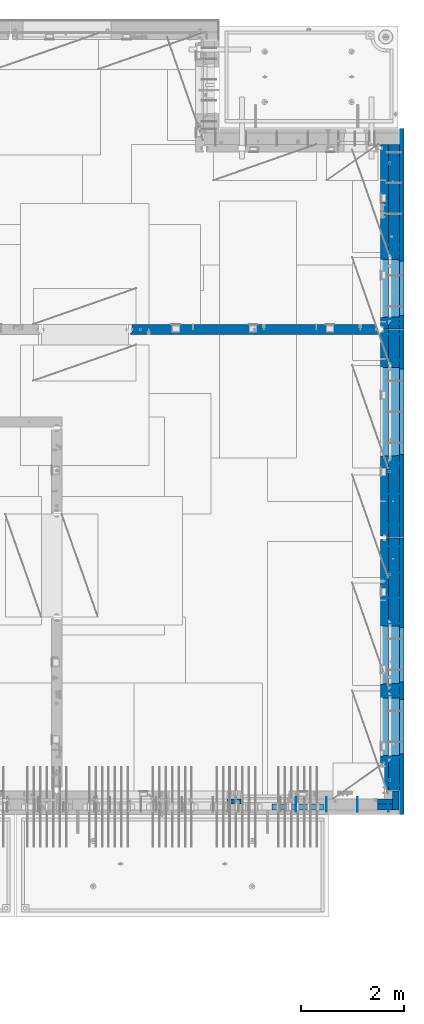
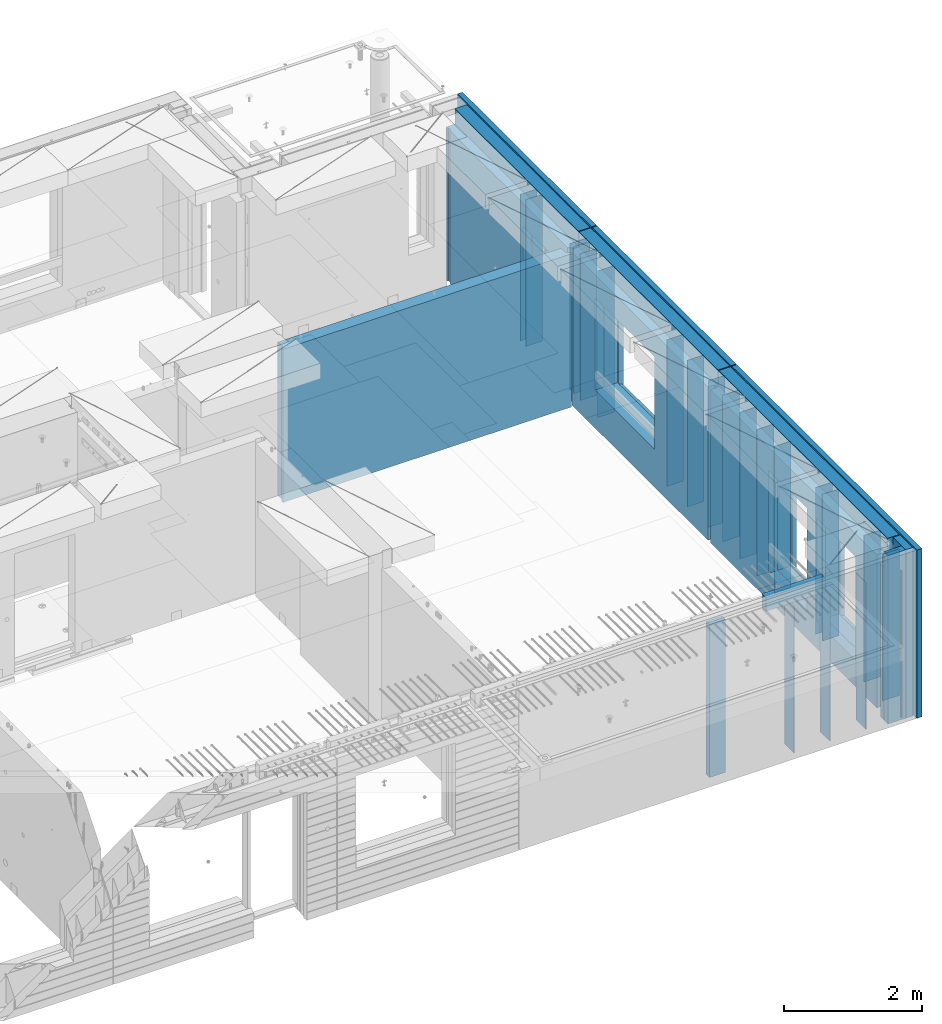
# One storey, part 243 of 352: 37 walls, 7 elements without a shape of their own.
"""IFC2X3 building model written with IfcOpenShell, lengths in millimetres."""

import ifcopenshell
import ifcopenshell.guid

model = None  # the IFC model being written
_history = None  # IfcOwnerHistory: only IFC2X3 demands one
_inside = {}  # id of a spatial element -> (the spatial element, [elements in it])
_under = {}  # id of a project, library or spatial element -> (it, [spatial elements below it])
_declared = {}  # id of a project -> (the project, [libraries it declares])
_typed = {}  # id of a type object -> (the type object, [elements of that type])
_made_of = {}  # id of a material, layer set ... -> (it, [elements and type objects made of it])


def new_model(schema):
    """Start an empty IFC model of exactly this schema.

    Asked for "IFC4X3", IfcOpenShell would pick the latest addendum, in which some entities
    have other attributes; the version numbers below select the first issue.
    IFC2X3 requires an IfcOwnerHistory on every rooted entity: one is made here for all.
    """
    global model, _history
    if schema == "IFC4X3":
        model = ifcopenshell.file(schema_version=(4, 3, 0, 0))
    else:
        model = ifcopenshell.file(schema=schema)
    _inside.clear()
    _under.clear()
    _declared.clear()
    _typed.clear()
    _made_of.clear()
    _history = None
    if model.schema == "IFC2X3":
        org = make("IfcOrganization", Name="unknown")
        user = make(
            "IfcPersonAndOrganization",
            ThePerson=make("IfcPerson", FamilyName="unknown"),
            TheOrganization=org,
        )
        app = make(
            "IfcApplication",
            ApplicationDeveloper=org,
            Version="unknown",
            ApplicationFullName="unknown",
            ApplicationIdentifier="unknown",
        )
        _history = make(
            "IfcOwnerHistory",
            OwningUser=user,
            OwningApplication=app,
            ChangeAction="ADDED",
            CreationDate=0,
        )
    return model


def make(cls, **values):
    """One entity of the class cls with the attributes given. An attribute that is None is left unset."""
    return model.create_entity(
        cls, **{name: value for name, value in values.items() if value is not None}
    )


def rooted(cls, **values):
    """An entity with a GlobalId (a new one), such as an element, a storey or a relation."""
    return make(cls, GlobalId=ifcopenshell.guid.new(), OwnerHistory=_history, **values)


def si_unit(unit_type, name, prefix=None):
    """IfcSIUnit, for example si_unit("LENGTHUNIT", "METRE", prefix="MILLI")."""
    return make("IfcSIUnit", UnitType=unit_type, Prefix=prefix, Name=name)


def assignment(units):
    """IfcUnitAssignment: the units of a project."""
    return None if units is None else make("IfcUnitAssignment", Units=units)


def point(xyz):
    """IfcCartesianPoint."""
    return None if xyz is None else make("IfcCartesianPoint", Coordinates=xyz)


def direction(xyz):
    """IfcDirection."""
    return None if xyz is None else make("IfcDirection", DirectionRatios=xyz)


def frame(location, z_axis=None, x_axis=None):
    """IfcAxis2Placement3D, a coordinate frame: its origin and axes. An axis left out is left unset."""
    return make(
        "IfcAxis2Placement3D",
        Location=point(location),
        Axis=direction(z_axis),
        RefDirection=direction(x_axis),
    )


def origin_with_axes():
    """The frame at (0, 0, 0) with the z axis (0, 0, 1) and the x axis (1, 0, 0) written out."""
    return frame((0.0, 0.0, 0.0), z_axis=(0.0, 0.0, 1.0), x_axis=(1.0, 0.0, 0.0))


def place(relative_to, where):
    """IfcLocalPlacement: puts the frame where relative to a parent placement (None: the world)."""
    return make(
        "IfcLocalPlacement", PlacementRelTo=relative_to, RelativePlacement=where
    )


def context(
    kind, dimensions, precision=None, world=None, true_north=None, identifier=None
):
    """IfcGeometricRepresentationContext, for example the 3D "Model" context."""
    return make(
        "IfcGeometricRepresentationContext",
        ContextIdentifier=identifier,
        ContextType=kind,
        CoordinateSpaceDimension=dimensions,
        Precision=precision,
        WorldCoordinateSystem=world,
        TrueNorth=true_north,
    )


def subcontext(parent, identifier, kind, view, scale=None):
    """IfcGeometricRepresentationSubContext, for example "Body" below "Model"."""
    return make(
        "IfcGeometricRepresentationSubContext",
        ContextIdentifier=identifier,
        ContextType=kind,
        ParentContext=parent,
        TargetScale=scale,
        TargetView=view,
    )


def project(units=None, contexts=None):
    """IfcProject with its units and contexts."""
    return rooted(
        "IfcProject",
        Name="project",
        RepresentationContexts=contexts,
        UnitsInContext=assignment(units),
    )


def spatial(cls, under=None, at=None, **own):
    """A site, building, storey or space (cls), placed at a placement, below another one or the project."""
    s = rooted(cls, ObjectPlacement=at, **own)
    if under is not None:
        _under.setdefault(under.id(), (under, []))[1].append(s)
    return s


def faces_of(points, faces, orient=None, outer=None):
    """IfcFace entities. A face is a list of loops; a loop is a list of indices into points, from 0.

    orient and outer hold one flag for each loop. By default every Orientation is true, the
    first loop of a face is its IfcFaceOuterBound and the others are IfcFaceBound.
    """
    made = []
    for i, loops in enumerate(faces):
        bounds = []
        for j, loop in enumerate(loops):
            is_outer = j == 0 if outer is None else outer[i][j]
            bounds.append(
                make(
                    "IfcFaceOuterBound" if is_outer else "IfcFaceBound",
                    Bound=make("IfcPolyLoop", Polygon=[points[k] for k in loop]),
                    Orientation=True if orient is None else orient[i][j],
                )
            )
        made.append(make("IfcFace", Bounds=bounds))
    return made


def faceted_brep(points, faces, orient=None, outer=None, voids=None):
    """IfcFacetedBrep: a solid bounded by flat faces; with voids (closed shells), ...WithVoids."""
    shared = [point(p) for p in points]
    hull = make("IfcClosedShell", CfsFaces=faces_of(shared, faces, orient, outer))
    if voids is None:
        return make("IfcFacetedBrep", Outer=hull)
    return make(
        "IfcFacetedBrepWithVoids",
        Outer=hull,
        Voids=[
            make(cls, CfsFaces=faces_of(shared, fs, o, b)) for cls, fs, o, b in voids
        ],
    )


def shape(context_of_items, identifier, shape_type, items):
    """IfcShapeRepresentation: the items that make up one representation, for example the "Body"."""
    return make(
        "IfcShapeRepresentation",
        ContextOfItems=context_of_items,
        RepresentationIdentifier=identifier,
        RepresentationType=shape_type,
        Items=items,
    )


def material(Name=None, Category=None):
    """IfcMaterial."""
    return make("IfcMaterial", Name=Name, Category=Category)


def made_of(thing, what):
    """Note that an element or type object is made of a material, layer set ...; save() writes the relation."""
    if what is not None:
        _made_of.setdefault(what.id(), (what, []))[1].append(thing)
    return thing


def type_object(cls, material=None, **own):
    """A type object (cls), such as IfcWallType, which elements share."""
    return made_of(rooted(cls, **own), material)


def element(
    cls,
    number,
    at=None,
    inside=None,
    cuts=None,
    type_object=None,
    material=None,
    context=None,
    identifier="Body",
    shape_type=None,
    held_by="IfcProductDefinitionShape",
    body=None,
    shapes=None,
    **own,
):
    """One element of the class cls, such as IfcWall. Its Tag is "e" and its number.

    at: its placement. inside: the storey or other place that contains it. cuts: it is an
    opening in that element (IfcRelVoidsElement). A single representation is given by context,
    identifier, shape_type and body (its items); several are given by shapes. held_by: the class
    of the entity that holds the representations. save() writes the other relations.
    """
    e = rooted(cls, Tag="e%d" % number, ObjectPlacement=at, **own)
    if body is not None:
        shapes = [shape(context, identifier, shape_type, body)]
    if shapes is not None:
        e.Representation = make(held_by, Representations=shapes)
    if inside is not None:
        _inside.setdefault(inside.id(), (inside, []))[1].append(e)
    if cuts is not None:
        rooted(
            "IfcRelVoidsElement", RelatingBuildingElement=cuts, RelatedOpeningElement=e
        )
    if type_object is not None:
        _typed.setdefault(type_object.id(), (type_object, []))[1].append(e)
    return made_of(e, material)


def aggregate(whole, parts):
    """IfcRelAggregates: a whole, such as a stair, and the parts it consists of."""
    return rooted("IfcRelAggregates", RelatingObject=whole, RelatedObjects=parts)


def save(model, path):
    """Write the relations noted so far, then the file.

    IfcRelAggregates (storeys below a building ...), IfcRelContainedInSpatialStructure (elements
    in a storey), IfcRelDefinesByType, IfcRelAssociatesMaterial and IfcRelDeclares: one each for
    every whole, place, type object, material and project.
    """
    for whole, parts in _under.values():
        aggregate(whole, parts)
    for where, things in _inside.values():
        rooted(
            "IfcRelContainedInSpatialStructure",
            RelatedElements=things,
            RelatingStructure=where,
        )
    for kind, things in _typed.values():
        rooted("IfcRelDefinesByType", RelatedObjects=things, RelatingType=kind)
    for what, things in _made_of.values():
        rooted("IfcRelAssociatesMaterial", RelatedObjects=things, RelatingMaterial=what)
    for by, libraries in _declared.values():
        rooted("IfcRelDeclares", RelatingContext=by, RelatedDefinitions=libraries)
    model.write(path)


model = new_model("IFC2X3")

# Units and contexts
model_context = context("Model", 3, precision=1e-05, world=origin_with_axes())
body_context = subcontext(model_context, "Body", "Model", "MODEL_VIEW")
ifc_project = project(units=[si_unit("LENGTHUNIT", "METRE", prefix="MILLI"), si_unit("AREAUNIT", "SQUARE_METRE"), si_unit("VOLUMEUNIT", "CUBIC_METRE"), si_unit("MASSUNIT", "GRAM", prefix="KILO"), si_unit("TIMEUNIT", "SECOND"), si_unit("PLANEANGLEUNIT", "RADIAN"), si_unit("SOLIDANGLEUNIT", "STERADIAN"), si_unit("THERMODYNAMICTEMPERATUREUNIT", "DEGREE_CELSIUS"), si_unit("LUMINOUSINTENSITYUNIT", "LUMEN")], contexts=[model_context])

# Site, building, storey
site_placement = place(None, origin_with_axes())
site = spatial("IfcSite", under=ifc_project, at=site_placement, CompositionType="ELEMENT")
building_placement = place(site_placement, origin_with_axes())
building = spatial("IfcBuilding", under=site, at=building_placement, CompositionType="ELEMENT")
storey_placement = place(building_placement, origin_with_axes())
storey = spatial("IfcBuildingStorey", under=building, at=storey_placement, Name="6", CompositionType="ELEMENT", Elevation=0.0)

# Assembly, walls
assembly_1_placement = place(storey_placement, origin_with_axes())
assembly_1 = element("IfcElementAssembly", 1, at=assembly_1_placement, inside=storey, AssemblyPlace="NOTDEFINED", PredefinedType="REINFORCEMENT_UNIT")
ifc_material_1 = material(Name="Undefined")
wall_type_1 = type_object("IfcWallType", PredefinedType="NOTDEFINED")
wall_1_placement = place(assembly_1_placement, frame((35030.0, 18465.0002441406, 98115.0), z_axis=(0.0, 0.0, 1.0), x_axis=(1.0, 0.0, 0.0)))
wall_1 = element("IfcWall", 2, at=wall_1_placement, type_object=wall_type_1, material=ifc_material_1, Name="(PD)", context=body_context, shape_type="Brep", body=[
    faceted_brep([(0.0, 5.0, -1300.0), (0.0, 5.0, 1300.0), (280.0, 5.0, 1300.0), (280.0, 5.0, -1300.0), (0.0, -5.0, 1300.0), (280.0, -5.0, 1300.0), (0.0, -5.0, -1300.0), (280.0, -5.0, -1300.0)], [[[0, 1, 2, 3]], [[1, 4, 5, 2]], [[4, 6, 7, 5]], [[6, 0, 3, 7]], [[5, 7, 3, 2]], [[6, 4, 1, 0]]]),
])
wall_2_placement = place(assembly_1_placement, frame((35030.0, 17085.0002441406, 98115.0), z_axis=(0.0, 0.0, 1.0), x_axis=(1.0, 0.0, 0.0)))
wall_2 = element("IfcWall", 3, at=wall_2_placement, type_object=wall_type_1, material=ifc_material_1, Name="(PD)", context=body_context, shape_type="Brep", body=[
    faceted_brep([(0.0, 5.0, -1300.0), (0.0, 5.0, 1300.0), (280.0, 5.0, 1300.0), (280.0, 5.0, -1300.0), (0.0, -5.0, 1300.0), (280.0, -5.0, 1300.0), (0.0, -5.0, -1300.0), (280.0, -5.0, -1300.0)], [[[0, 1, 2, 3]], [[1, 4, 5, 2]], [[4, 6, 7, 5]], [[6, 0, 3, 7]], [[5, 7, 3, 2]], [[6, 4, 1, 0]]]),
])
wall_3_placement = place(assembly_1_placement, frame((35030.0, 17185.0002441406, 98115.0), z_axis=(0.0, 0.0, 1.0), x_axis=(1.0, 0.0, 0.0)))
wall_3 = element("IfcWall", 4, at=wall_3_placement, type_object=wall_type_1, material=ifc_material_1, Name="(PD)", context=body_context, shape_type="Brep", body=[
    faceted_brep([(0.0, 5.0, -1300.0), (0.0, 5.0, 1300.0), (280.0, 5.0, 1300.0), (280.0, 5.0, -1300.0), (0.0, -5.0, 1300.0), (280.0, -5.0, 1300.0), (0.0, -5.0, -1300.0), (280.0, -5.0, -1300.0)], [[[0, 1, 2, 3]], [[1, 4, 5, 2]], [[4, 6, 7, 5]], [[6, 0, 3, 7]], [[5, 7, 3, 2]], [[6, 4, 1, 0]]]),
])
wall_4_placement = place(assembly_1_placement, frame((35030.0, 18625.0002441406, 98115.0), z_axis=(0.0, 0.0, 1.0), x_axis=(1.0, 0.0, 0.0)))
wall_4 = element("IfcWall", 5, at=wall_4_placement, type_object=wall_type_1, material=ifc_material_1, Name="(PD)", context=body_context, shape_type="Brep", body=[
    faceted_brep([(0.0, 5.0, -1300.0), (0.0, 5.0, 1300.0), (280.0, 5.0, 1300.0), (280.0, 5.0, -1300.0), (0.0, -5.0, 1300.0), (280.0, -5.0, 1300.0), (0.0, -5.0, -1300.0), (280.0, -5.0, -1300.0)], [[[0, 1, 2, 3]], [[1, 4, 5, 2]], [[4, 6, 7, 5]], [[6, 0, 3, 7]], [[5, 7, 3, 2]], [[6, 4, 1, 0]]]),
])

assembly_2_placement = place(storey_placement, origin_with_axes())
assembly_2 = element("IfcElementAssembly", 6, at=assembly_2_placement, inside=storey, AssemblyPlace="NOTDEFINED", PredefinedType="REINFORCEMENT_UNIT")
wall_5_placement = place(assembly_2_placement, frame((35060.0, 7780.0, 98115.0), z_axis=(0.0, 0.0, 1.0), x_axis=(0.0, -1.0, 0.0)))
wall_5 = element("IfcWall", 7, at=wall_5_placement, type_object=wall_type_1, material=ifc_material_1, Name="(PD)", context=body_context, shape_type="Brep", body=[
    faceted_brep([(0.0, 5.0, -1300.0), (0.0, 5.0, 1300.0), (180.0, 5.0, 1300.0), (180.0, 5.0, -1300.0), (0.0, -5.0, 1300.0), (180.0, -5.0, 1300.0), (0.0, -5.0, -1300.0), (180.0, -5.0, -1300.0)], [[[0, 1, 2, 3]], [[1, 4, 5, 2]], [[4, 6, 7, 5]], [[6, 0, 3, 7]], [[5, 7, 3, 2]], [[6, 4, 1, 0]]]),
])
wall_6_placement = place(assembly_2_placement, frame((34460.0, 7880.0, 98115.0), z_axis=(0.0, 0.0, 1.0), x_axis=(0.0, -1.0, 0.0)))
wall_6 = element("IfcWall", 8, at=wall_6_placement, type_object=wall_type_1, material=ifc_material_1, Name="(PD)", context=body_context, shape_type="Brep", body=[
    faceted_brep([(0.0, 5.0, -1300.0), (0.0, 5.0, 1300.0), (280.0, 5.0, 1300.0), (280.0, 5.0, -1300.0), (0.0, -5.0, 1300.0), (280.0, -5.0, 1300.0), (0.0, -5.0, -1300.0), (280.0, -5.0, -1300.0)], [[[0, 1, 2, 3]], [[1, 4, 5, 2]], [[4, 6, 7, 5]], [[6, 0, 3, 7]], [[5, 7, 3, 2]], [[6, 4, 1, 0]]]),
])
wall_7_placement = place(assembly_2_placement, frame((33860.0, 7880.0, 98115.0), z_axis=(0.0, 0.0, 1.0), x_axis=(0.0, -1.0, 0.0)))
wall_7 = element("IfcWall", 9, at=wall_7_placement, type_object=wall_type_1, material=ifc_material_1, Name="(PD)", context=body_context, shape_type="Brep", body=[
    faceted_brep([(0.0, 5.0, -1300.0), (0.0, 5.0, 1300.0), (280.0, 5.0, 1300.0), (280.0, 5.0, -1300.0), (0.0, -5.0, 1300.0), (280.0, -5.0, 1300.0), (0.0, -5.0, -1300.0), (280.0, -5.0, -1300.0)], [[[0, 1, 2, 3]], [[1, 4, 5, 2]], [[4, 6, 7, 5]], [[6, 0, 3, 7]], [[5, 7, 3, 2]], [[6, 4, 1, 0]]]),
])

assembly_3_placement = place(storey_placement, origin_with_axes())
assembly_3 = element("IfcElementAssembly", 10, at=assembly_3_placement, inside=storey, AssemblyPlace="NOTDEFINED", PredefinedType="REINFORCEMENT_UNIT")
wall_8_placement = place(assembly_3_placement, frame((35030.0, 12755.0002861023, 98115.0), z_axis=(0.0, 0.0, 1.0), x_axis=(1.0, 0.0, 0.0)))
wall_8 = element("IfcWall", 11, at=wall_8_placement, type_object=wall_type_1, material=ifc_material_1, Name="(PD)", context=body_context, shape_type="Brep", body=[
    faceted_brep([(0.0, 5.0, -1300.0), (0.0, 5.0, 1300.0), (280.0, 5.0, 1300.0), (280.0, 5.0, -1300.0), (0.0, -5.0, 1300.0), (280.0, -5.0, 1300.0), (0.0, -5.0, -1300.0), (280.0, -5.0, -1300.0)], [[[0, 1, 2, 3]], [[1, 4, 5, 2]], [[4, 6, 7, 5]], [[6, 0, 3, 7]], [[5, 7, 3, 2]], [[6, 4, 1, 0]]]),
])
wall_9_placement = place(assembly_3_placement, frame((35030.0, 12255.0002861023, 98115.0), z_axis=(0.0, 0.0, 1.0), x_axis=(1.0, 0.0, 0.0)))
wall_9 = element("IfcWall", 12, at=wall_9_placement, type_object=wall_type_1, material=ifc_material_1, Name="(PD)", context=body_context, shape_type="Brep", body=[
    faceted_brep([(0.0, 5.0, -1300.0), (0.0, 5.0, 1300.0), (280.0, 5.0, 1300.0), (280.0, 5.0, -1300.0), (0.0, -5.0, 1300.0), (280.0, -5.0, 1300.0), (0.0, -5.0, -1300.0), (280.0, -5.0, -1300.0)], [[[0, 1, 2, 3]], [[1, 4, 5, 2]], [[4, 6, 7, 5]], [[6, 0, 3, 7]], [[5, 7, 3, 2]], [[6, 4, 1, 0]]]),
])
wall_10_placement = place(assembly_3_placement, frame((35030.0, 11755.0002861023, 98115.0), z_axis=(0.0, 0.0, 1.0), x_axis=(1.0, 0.0, 0.0)))
wall_10 = element("IfcWall", 13, at=wall_10_placement, type_object=wall_type_1, material=ifc_material_1, Name="(PD)", context=body_context, shape_type="Brep", body=[
    faceted_brep([(0.0, 5.0, -1300.0), (0.0, 5.0, 1300.0), (280.0, 5.0, 1300.0), (280.0, 5.0, -1300.0), (0.0, -5.0, 1300.0), (280.0, -5.0, 1300.0), (0.0, -5.0, -1300.0), (280.0, -5.0, -1300.0)], [[[0, 1, 2, 3]], [[1, 4, 5, 2]], [[4, 6, 7, 5]], [[6, 0, 3, 7]], [[5, 7, 3, 2]], [[6, 4, 1, 0]]]),
])
wall_11_placement = place(assembly_3_placement, frame((35030.0, 11255.0002861023, 98115.0), z_axis=(0.0, 0.0, 1.0), x_axis=(1.0, 0.0, 0.0)))
wall_11 = element("IfcWall", 14, at=wall_11_placement, type_object=wall_type_1, material=ifc_material_1, Name="(PD)", context=body_context, shape_type="Brep", body=[
    faceted_brep([(0.0, 5.0, -1300.0), (0.0, 5.0, 1300.0), (280.0, 5.0, 1300.0), (280.0, 5.0, -1300.0), (0.0, -5.0, 1300.0), (280.0, -5.0, 1300.0), (0.0, -5.0, -1300.0), (280.0, -5.0, -1300.0)], [[[0, 1, 2, 3]], [[1, 4, 5, 2]], [[4, 6, 7, 5]], [[6, 0, 3, 7]], [[5, 7, 3, 2]], [[6, 4, 1, 0]]]),
])
wall_12_placement = place(assembly_3_placement, frame((35030.0, 8105.0, 98115.0), z_axis=(0.0, 0.0, 1.0), x_axis=(1.0, 0.0, 0.0)))
wall_12 = element("IfcWall", 15, at=wall_12_placement, type_object=wall_type_1, material=ifc_material_1, Name="(PD)", context=body_context, shape_type="Brep", body=[
    faceted_brep([(0.0, 5.0, -1300.0), (0.0, 5.0, 1300.0), (280.0, 5.0, 1300.0), (280.0, 5.0, -1300.0), (0.0, -5.0, 1300.0), (280.0, -5.0, 1300.0), (0.0, -5.0, -1300.0), (280.0, -5.0, -1300.0)], [[[0, 1, 2, 3]], [[1, 4, 5, 2]], [[4, 6, 7, 5]], [[6, 0, 3, 7]], [[5, 7, 3, 2]], [[6, 4, 1, 0]]]),
])
wall_13_placement = place(assembly_3_placement, frame((35030.0, 8115.0, 98115.0), z_axis=(0.0, 0.0, 1.0), x_axis=(1.0, 0.0, 0.0)))
wall_13 = element("IfcWall", 16, at=wall_13_placement, type_object=wall_type_1, material=ifc_material_1, Name="(PD)", context=body_context, shape_type="Brep", body=[
    faceted_brep([(0.0, 5.0, -1300.0), (0.0, 5.0, 1300.0), (280.0, 5.0, 1300.0), (280.0, 5.0, -1300.0), (0.0, -5.0, 1300.0), (280.0, -5.0, 1300.0), (0.0, -5.0, -1300.0), (280.0, -5.0, -1300.0)], [[[0, 1, 2, 3]], [[1, 4, 5, 2]], [[4, 6, 7, 5]], [[6, 0, 3, 7]], [[5, 7, 3, 2]], [[6, 4, 1, 0]]]),
])
wall_14_placement = place(assembly_3_placement, frame((35030.0, 9855.00028610229, 98115.0), z_axis=(0.0, 0.0, 1.0), x_axis=(1.0, 0.0, 0.0)))
wall_14 = element("IfcWall", 17, at=wall_14_placement, type_object=wall_type_1, material=ifc_material_1, Name="(PD)", context=body_context, shape_type="Brep", body=[
    faceted_brep([(0.0, 5.0, -1300.0), (0.0, 5.0, 1300.0), (280.0, 5.0, 1300.0), (280.0, 5.0, -1300.0), (0.0, -5.0, 1300.0), (280.0, -5.0, 1300.0), (0.0, -5.0, -1300.0), (280.0, -5.0, -1300.0)], [[[0, 1, 2, 3]], [[1, 4, 5, 2]], [[4, 6, 7, 5]], [[6, 0, 3, 7]], [[5, 7, 3, 2]], [[6, 4, 1, 0]]]),
])
wall_15_placement = place(assembly_3_placement, frame((35030.0, 10055.0002861023, 98115.0), z_axis=(0.0, 0.0, 1.0), x_axis=(1.0, 0.0, 0.0)))
wall_15 = element("IfcWall", 18, at=wall_15_placement, type_object=wall_type_1, material=ifc_material_1, Name="(PD)", context=body_context, shape_type="Brep", body=[
    faceted_brep([(0.0, 5.0, -1300.0), (0.0, 5.0, 1300.0), (280.0, 5.0, 1300.0), (280.0, 5.0, -1300.0), (0.0, -5.0, 1300.0), (280.0, -5.0, 1300.0), (0.0, -5.0, -1300.0), (280.0, -5.0, -1300.0)], [[[0, 1, 2, 3]], [[1, 4, 5, 2]], [[4, 6, 7, 5]], [[6, 0, 3, 7]], [[5, 7, 3, 2]], [[6, 4, 1, 0]]]),
])

assembly_4_placement = place(storey_placement, origin_with_axes())
assembly_4 = element("IfcElementAssembly", 19, at=assembly_4_placement, inside=storey, AssemblyPlace="NOTDEFINED", PredefinedType="REINFORCEMENT_UNIT")
wall_16_placement = place(assembly_4_placement, frame((35030.0, 13175.0002861023, 98115.0), z_axis=(0.0, 0.0, 1.0), x_axis=(1.0, 0.0, 0.0)))
wall_16 = element("IfcWall", 20, at=wall_16_placement, type_object=wall_type_1, material=ifc_material_1, Name="(PD)", context=body_context, shape_type="Brep", body=[
    faceted_brep([(0.0, 5.0, -1300.0), (0.0, 5.0, 1300.0), (280.0, 5.0, 1300.0), (280.0, 5.0, -1300.0), (0.0, -5.0, 1300.0), (280.0, -5.0, 1300.0), (0.0, -5.0, -1300.0), (280.0, -5.0, -1300.0)], [[[0, 1, 2, 3]], [[1, 4, 5, 2]], [[4, 6, 7, 5]], [[6, 0, 3, 7]], [[5, 7, 3, 2]], [[6, 4, 1, 0]]]),
])
wall_17_placement = place(assembly_4_placement, frame((35030.0, 13775.0002861023, 98115.0), z_axis=(0.0, 0.0, 1.0), x_axis=(1.0, 0.0, 0.0)))
wall_17 = element("IfcWall", 21, at=wall_17_placement, type_object=wall_type_1, material=ifc_material_1, Name="(PD)", context=body_context, shape_type="Brep", body=[
    faceted_brep([(0.0, 5.0, -1300.0), (0.0, 5.0, 1300.0), (280.0, 5.0, 1300.0), (280.0, 5.0, -1300.0), (0.0, -5.0, 1300.0), (280.0, -5.0, 1300.0), (0.0, -5.0, -1300.0), (280.0, -5.0, -1300.0)], [[[0, 1, 2, 3]], [[1, 4, 5, 2]], [[4, 6, 7, 5]], [[6, 0, 3, 7]], [[5, 7, 3, 2]], [[6, 4, 1, 0]]]),
])
wall_18_placement = place(assembly_4_placement, frame((35030.0, 16885.0002861023, 98115.0), z_axis=(0.0, 0.0, 1.0), x_axis=(1.0, 0.0, 0.0)))
wall_18 = element("IfcWall", 22, at=wall_18_placement, type_object=wall_type_1, material=ifc_material_1, Name="(PD)", context=body_context, shape_type="Brep", body=[
    faceted_brep([(0.0, 5.0, -1300.0), (0.0, 5.0, 1300.0), (280.0, 5.0, 1300.0), (280.0, 5.0, -1300.0), (0.0, -5.0, 1300.0), (280.0, -5.0, 1300.0), (0.0, -5.0, -1300.0), (280.0, -5.0, -1300.0)], [[[0, 1, 2, 3]], [[1, 4, 5, 2]], [[4, 6, 7, 5]], [[6, 0, 3, 7]], [[5, 7, 3, 2]], [[6, 4, 1, 0]]]),
])
wall_19_placement = place(assembly_4_placement, frame((35030.0, 16385.0002861023, 98115.0), z_axis=(0.0, 0.0, 1.0), x_axis=(1.0, 0.0, 0.0)))
wall_19 = element("IfcWall", 23, at=wall_19_placement, type_object=wall_type_1, material=ifc_material_1, Name="(PD)", context=body_context, shape_type="Brep", body=[
    faceted_brep([(0.0, 5.0, -1300.0), (0.0, 5.0, 1300.0), (280.0, 5.0, 1300.0), (280.0, 5.0, -1300.0), (0.0, -5.0, 1300.0), (280.0, -5.0, 1300.0), (0.0, -5.0, -1300.0), (280.0, -5.0, -1300.0)], [[[0, 1, 2, 3]], [[1, 4, 5, 2]], [[4, 6, 7, 5]], [[6, 0, 3, 7]], [[5, 7, 3, 2]], [[6, 4, 1, 0]]]),
])

# Wall
wall_20_placement = place(assembly_2_placement, frame((33260.0, 7880.0, 98115.0), z_axis=(0.0, 0.0, 1.0), x_axis=(0.0, -1.0, 0.0)))
wall_20 = element("IfcWall", 24, at=wall_20_placement, type_object=wall_type_1, material=ifc_material_1, Name="(PD)", context=body_context, shape_type="Brep", body=[
    faceted_brep([(0.0, 5.0, -1300.0), (0.0, 5.0, 1300.0), (280.0, 5.0, 1300.0), (280.0, 5.0, -1300.0), (0.0, -5.0, 1300.0), (280.0, -5.0, 1300.0), (0.0, -5.0, -1300.0), (280.0, -5.0, -1300.0)], [[[0, 1, 2, 3]], [[1, 4, 5, 2]], [[4, 6, 7, 5]], [[6, 0, 3, 7]], [[5, 7, 3, 2]], [[6, 4, 1, 0]]]),
])

wall_21_placement = place(assembly_3_placement, frame((35030.0, 8655.0, 98115.0), z_axis=(0.0, 0.0, 1.0), x_axis=(1.0, 0.0, 0.0)))
wall_21 = element("IfcWall", 25, at=wall_21_placement, type_object=wall_type_1, material=ifc_material_1, Name="(PD)", context=body_context, shape_type="Brep", body=[
    faceted_brep([(0.0, 5.0, -1300.0), (0.0, 5.0, 1300.0), (280.0, 5.0, 1300.0), (280.0, 5.0, -1300.0), (0.0, -5.0, 1300.0), (280.0, -5.0, 1300.0), (0.0, -5.0, -1300.0), (280.0, -5.0, -1300.0)], [[[0, 1, 2, 3]], [[1, 4, 5, 2]], [[4, 6, 7, 5]], [[6, 0, 3, 7]], [[5, 7, 3, 2]], [[6, 4, 1, 0]]]),
])

wall_22_placement = place(assembly_4_placement, frame((35030.0, 14375.0002861023, 98115.0), z_axis=(0.0, 0.0, 1.0), x_axis=(1.0, 0.0, 0.0)))
wall_22 = element("IfcWall", 26, at=wall_22_placement, type_object=wall_type_1, material=ifc_material_1, Name="(PD)", context=body_context, shape_type="Brep", body=[
    faceted_brep([(0.0, 5.0, -1300.0), (0.0, 5.0, 1300.0), (280.0, 5.0, 1300.0), (280.0, 5.0, -1300.0), (0.0, -5.0, 1300.0), (280.0, -5.0, 1300.0), (0.0, -5.0, -1300.0), (280.0, -5.0, -1300.0)], [[[0, 1, 2, 3]], [[1, 4, 5, 2]], [[4, 6, 7, 5]], [[6, 0, 3, 7]], [[5, 7, 3, 2]], [[6, 4, 1, 0]]]),
])

# Assembly, wall
assembly_5_placement = place(storey_placement, origin_with_axes())
assembly_5 = element("IfcElementAssembly", 27, at=assembly_5_placement, inside=storey, AssemblyPlace="NOTDEFINED", PredefinedType="REINFORCEMENT_UNIT")
ifc_material_2 = material(Name="CONCRETE/C25/30")
wall_type_2 = type_object("IfcWallType", PredefinedType="NOTDEFINED")
wall_23_placement = place(assembly_5_placement, frame((30040.0, 16980.0002441406, 98112.5), z_axis=(0.0, 0.0, 1.0), x_axis=(1.0, 0.0, 0.0)))
wall_23 = element("IfcWall", 28, at=wall_23_placement, type_object=wall_type_2, material=ifc_material_2, context=body_context, shape_type="Brep", body=[
    faceted_brep([(4785.0, 100.0, 1357.5), (4785.0, -30.0, 1357.5), (4785.0, -30.0, -1357.5), (4785.0, 100.0, -1357.5), (4840.0, -60.0, 1357.5), (4840.0, -60.0, -1357.5), (30.0003214753524, 100.0, 1357.5), (30.0003214753524, 100.0, -1357.5), (30.0003214753524, -57.0, -1357.5), (30.0003214753524, -57.0, 1357.5), (0.0, -70.0001393059865, -1357.5), (0.0, -70.0001393059865, 1357.5), (0.0, -100.0, -1357.5), (0.0, -100.0, 1357.5), (4840.0, -100.0, -1357.5), (4840.0, -100.0, 1357.5)], [[[0, 1, 2, 3]], [[4, 5, 2, 1]], [[6, 7, 8, 9]], [[9, 8, 10, 11]], [[12, 13, 11, 10]], [[13, 12, 14, 15]], [[0, 6, 9, 11, 13, 15, 4, 1]], [[7, 6, 0, 3]], [[14, 12, 10, 8, 7, 3, 2, 5]], [[15, 14, 5, 4]]]),
])
aggregate(assembly_5, [wall_23])

# Assemblies, wall
assembly_6_placement = place(storey_placement, origin_with_axes())
assembly_6 = element("IfcElementAssembly", 29, at=assembly_6_placement, inside=storey, AssemblyPlace="NOTDEFINED", PredefinedType="REINFORCEMENT_UNIT")
assembly_7_placement = place(assembly_6_placement, origin_with_axes())
assembly_7 = element("IfcElementAssembly", 30, at=assembly_7_placement, Name="Steel Assembly", AssemblyPlace="NOTDEFINED", PredefinedType="NOTDEFINED")
aggregate(assembly_6, [assembly_7])
ifc_material_3 = material()
wall_type_3 = type_object("IfcWallType", PredefinedType="NOTDEFINED")
wall_24_placement = place(assembly_7_placement, frame((32799.9998568133, 7690.00021946163, 99590.0), z_axis=(0.0, 0.0, 1.0), x_axis=(1.0, 0.0, 0.0)))
wall_24 = element("IfcWall", 31, at=wall_24_placement, type_object=wall_type_3, material=ifc_material_3, context=body_context, shape_type="Brep", body=[
    faceted_brep([(0.0, 60.0, -120.0), (0.0, 60.0, 120.0), (1000.0, 60.0, 120.0), (1000.0, 60.0, -120.0), (0.0, -60.0, 120.0), (1000.0, -60.0, 120.0), (0.0, -60.0, -120.0), (1000.0, -60.0, -120.0)], [[[0, 1, 2, 3]], [[1, 4, 5, 2]], [[4, 6, 7, 5]], [[6, 0, 3, 7]], [[5, 7, 3, 2]], [[6, 4, 1, 0]]]),
])
aggregate(assembly_7, [wall_24])

# Wall
ifc_material_4 = material(Name="COS5gt")
wall_type_4 = type_object("IfcWallType", PredefinedType="NOTDEFINED")
wall_25_placement = place(assembly_1_placement, frame((35170.0, 20575.0002441406, 98247.5), z_axis=(0.0, 0.0, 1.0), x_axis=(0.0, -1.0, 0.0)))
wall_25 = element("IfcWall", 32, at=wall_25_placement, type_object=wall_type_4, material=ifc_material_4, context=body_context, shape_type="Brep", body=[
    faceted_brep([(0.0, 90.0, 1492.5), (3585.0, 90.0, 1492.5), (3585.0, 90.0, 1442.5), (0.0, 90.0, 1442.5), (0.0, -110.0, 1492.5), (3585.0, -110.0, 1492.5), (3585.0, 110.0, 1442.5), (3585.0, -110.0, -1492.5), (3585.0, 90.0, -1492.5), (3585.0, 90.0, -1442.5), (3585.0, 110.0, -1442.5), (0.0, 110.0, 1442.5), (0.0, 90.0, -1492.5), (0.0, -110.0, -1492.5), (0.0, 110.0, -1442.5), (0.0, 90.0, -1442.5), (2239.99987343476, 110.0, -807.5), (2269.99987343476, 110.0, -807.5), (3319.99987343476, 110.0, -807.5), (3349.99987343476, 110.0, -807.5), (3349.99987343476, 110.0, -802.5), (3349.99987343476, 110.0, 807.5), (2239.99987343476, 110.0, 807.5), (2239.99987343476, 110.0, -802.5), (3355.94581938071, -110.0, -813.445945945947), (3355.94581938071, -110.0, 813.445945945947), (2234.05392748882, -110.0, -813.445945945947), (2234.05392748882, -110.0, 813.445945945947)], [[[0, 1, 2, 3]], [[4, 5, 1, 0]], [[6, 2, 1, 5, 7, 8, 9, 10]], [[11, 3, 2, 6]], [[12, 13, 4, 0, 3, 11, 14, 15]], [[7, 13, 12, 8]], [[15, 9, 8, 12]], [[14, 10, 9, 15]], [[11, 6, 10, 14], [16, 17, 18, 19, 20, 21, 22, 23]], [[20, 19, 24, 25, 21]], [[18, 17, 16, 26, 24, 19]], [[23, 22, 27, 26, 16]], [[21, 25, 27, 22]], [[4, 13, 7, 5], [24, 26, 27, 25]]]),
])

wall_26_placement = place(assembly_3_placement, frame((35170.0, 12920.0002861023, 98247.5), z_axis=(0.0, 0.0, 1.0), x_axis=(0.0, -1.0, 0.0)))
wall_26 = element("IfcWall", 33, at=wall_26_placement, type_object=wall_type_4, material=ifc_material_4, context=body_context, shape_type="Brep", body=[
    faceted_brep([(0.0, 90.0, 1492.5), (4905.00028610229, 90.0, 1492.5), (4905.00028610229, 90.0, 1442.5), (-0.25, 90.0, 1442.5), (0.0, -110.0, 1492.5), (4905.00028610229, -110.0, 1492.5), (4905.00028610229, 110.0, 1442.5), (4905.00028610229, -110.0, -1492.5), (4905.00028610229, 90.0, -1492.5), (4905.00028610229, 90.0, -1442.5), (4905.00028610229, 110.0, -1442.5), (-0.25, 110.0, 1442.5), (0.0, 90.0, -1492.5), (0.0, -110.0, -1492.5), (-0.25, 110.0, -1442.5), (-0.25, 90.0, -1442.5), (3115.00024333302, 110.0, -1007.5), (3145.00024333302, 110.0, -1007.5), (4195.00024333302, 110.0, -1007.5), (4225.00024333302, 110.0, -1007.5), (4225.00024333302, 110.0, -1002.5), (4225.00024333302, 110.0, 807.5), (3115.00024333302, 110.0, 807.5), (3115.00024333302, 110.0, -1002.5), (1715.00062480275, 110.0, -1007.5), (1745.00062480275, 110.0, -1007.5), (2795.00062480275, 110.0, -1007.5), (2825.00062480275, 110.0, -1007.5), (2825.00062480275, 110.0, -1002.5), (2825.00062480275, 110.0, 807.5), (1715.00062480275, 110.0, 807.5), (1715.00062480275, 110.0, -1002.5), (4230.94618927897, -110.0, -1013.44594594595), (4230.94618927897, -110.0, 813.445945945947), (3109.05429738708, -110.0, -1013.44594594595), (3109.05429738708, -110.0, 813.445945945947), (2830.9465707487, -110.0, -1013.44594594595), (1709.0546788568, -110.0, -1013.44594594595), (1709.0546788568, -110.0, 813.445945945947), (2830.9465707487, -110.0, 813.445945945947)], [[[0, 1, 2, 3]], [[4, 5, 1, 0]], [[6, 2, 1, 5, 7, 8, 9, 10]], [[11, 3, 2, 6]], [[12, 13, 4, 0, 3, 11, 14, 15]], [[7, 13, 12, 8]], [[15, 9, 8, 12]], [[14, 10, 9, 15]], [[11, 6, 10, 14], [16, 17, 18, 19, 20, 21, 22, 23], [24, 25, 26, 27, 28, 29, 30, 31]], [[20, 19, 32, 33, 21]], [[18, 17, 16, 34, 32, 19]], [[23, 22, 35, 34, 16]], [[21, 33, 35, 22]], [[4, 13, 7, 5], [32, 34, 35, 33], [36, 37, 38, 39]], [[26, 25, 24, 37, 36, 27]], [[31, 30, 38, 37, 24]], [[29, 39, 38, 30]], [[28, 27, 36, 39, 29]]]),
])

wall_27_placement = place(assembly_4_placement, frame((35170.0, 16980.0002861023, 98247.5), z_axis=(0.0, 0.0, 1.0), x_axis=(0.0, -1.0, 0.0)))
wall_27 = element("IfcWall", 34, at=wall_27_placement, type_object=wall_type_4, material=ifc_material_4, context=body_context, shape_type="Brep", body=[
    faceted_brep([(1409.0, 90.0, -1492.5), (1409.0, 90.0, -1442.5), (4045.0, 90.0, -1442.5), (4045.0, 90.0, -1492.5), (5.0, 110.0, -1492.5), (5.0, -110.0, -1492.5), (5.0, -110.0, 1492.5), (5.00004196166992, 90.0, 1492.5), (5.00004196166992, 90.0, 1442.5), (5.00004196166992, 110.0, 1442.5), (4045.0, -110.0, -1492.5), (4045.0, -110.0, 1492.5), (2460.94588410319, -110.0, -813.445945945947), (739.053992211293, -110.0, -813.445945945947), (739.053992211293, -110.0, 813.445945945947), (2460.94588410319, -110.0, 813.445945945947), (2454.99993815724, 110.0, 807.5), (744.99993815724, 110.0, 807.5), (2454.99993815724, 110.0, -802.5), (2454.99993815724, 110.0, -807.5), (2424.99993815724, 110.0, -807.5), (774.99993815724, 110.0, -807.5), (744.99993815724, 110.0, -807.5), (744.99993815724, 110.0, -802.5), (4045.0, 110.0, 1442.5), (4045.0, 110.0, -1442.5), (1409.0, 110.0, -1442.5), (1409.0, 110.0, -1492.5), (4045.0, 90.0, 1442.5), (4045.0, 90.0, 1492.5)], [[[0, 1, 2, 3]], [[4, 5, 6, 7, 8, 9]], [[6, 5, 10, 11], [12, 13, 14, 15]], [[16, 15, 14, 17]], [[18, 19, 12, 15, 16]], [[20, 21, 22, 13, 12, 19]], [[23, 17, 14, 13, 22]], [[4, 9, 24, 25, 26, 27], [22, 21, 20, 19, 18, 16, 17, 23]], [[3, 10, 5, 4, 27, 0]], [[26, 1, 0, 27]], [[25, 2, 1, 26]], [[24, 28, 29, 11, 10, 3, 2, 25]], [[9, 8, 28, 24]], [[7, 29, 28, 8]], [[6, 11, 29, 7]]]),
])

ifc_material_5 = material(Name="CONCRETE/C30/37")
wall_type_5 = type_object("IfcWallType", PredefinedType="NOTDEFINED")
wall_28_placement = place(assembly_1_placement, frame((35322.5, 20432.0002441406, 98247.5), z_axis=(0.0, 0.0, 1.0), x_axis=(0.0, -1.0, 0.0)))
wall_28 = element("IfcWall", 35, at=wall_28_placement, type_object=wall_type_5, material=ifc_material_5, context=body_context, shape_type="Brep", body=[
    faceted_brep([(-453.0, -42.5, -1492.5), (-453.0, -42.5, 1492.5), (-453.0, 42.5, 1492.5), (-453.0, 42.5, -1492.5), (3442.0, 42.5, -1492.5), (3442.0, -42.5, -1492.5), (3442.0, -42.5, 1492.5), (3176.99987343476, -42.5, 782.5), (3176.99987343476, -42.5, -807.5), (2126.99987343476, -42.5, -807.5), (2126.99987343476, -42.5, 782.5), (2126.99987343476, -42.5, 787.5), (3176.99987343476, -42.5, 787.5), (2126.99987343476, 42.5, 782.5), (3176.99987343476, 42.5, 782.5), (3186.99987343476, 42.5, 782.5), (2116.99987343476, 42.5, 782.5), (3186.99987343476, 42.5, -857.5), (2116.99987343476, 42.5, -857.5), (3442.0, 42.5, 1492.5)], [[[0, 1, 2, 3]], [[0, 3, 4, 5]], [[1, 0, 5, 6], [7, 8, 9, 10, 11, 12]], [[13, 14, 15, 12, 11, 16]], [[17, 8, 7, 12, 15]], [[18, 9, 8, 17]], [[16, 11, 10, 9, 18]], [[3, 2, 19, 4], [17, 15, 14, 13, 16, 18]], [[6, 5, 4, 19]], [[2, 1, 6, 19]]]),
])

wall_29_placement = place(assembly_3_placement, frame((35322.5, 12920.2502861023, 98247.5), z_axis=(0.0, 0.0, 1.0), x_axis=(0.0, -1.0, 0.0)))
wall_29 = element("IfcWall", 36, at=wall_29_placement, type_object=wall_type_5, material=ifc_material_5, context=body_context, shape_type="Brep", body=[
    faceted_brep([(0.0, 42.5, 1492.5), (0.0, -42.5, 1492.5), (5375.25028610229, -42.5, 1492.5), (5375.25028610229, 42.5, 1492.5), (0.0, -42.5, -1492.5), (0.0, 42.5, -1492.5), (5375.25028610229, 42.5, -1492.5), (5375.25028610229, -42.5, -1492.5), (4205.25024333302, 42.5, -1057.5), (4195.25024333302, -42.5, -1007.5), (4195.25024333302, -42.5, 782.5), (4195.25024333302, -42.5, 787.5), (4205.25024333302, 42.5, 782.5), (3135.25024333302, 42.5, -1057.5), (3145.25024333302, -42.5, -1007.5), (3135.25024333302, 42.5, 782.5), (3145.25024333302, -42.5, 787.5), (3145.25024333302, -42.5, 782.5), (3145.25024333302, 42.5, 782.5), (4195.25024333302, 42.5, 782.5), (2795.25062480275, -42.5, 782.5), (2795.25062480275, -42.5, -1007.5), (1745.25062480275, -42.5, -1007.5), (1745.25062480275, -42.5, 782.5), (1745.25062480275, -42.5, 787.5), (2795.25062480275, -42.5, 787.5), (1745.25062480275, 42.5, 782.5), (2795.25062480275, 42.5, 782.5), (2805.25062480275, 42.5, 782.5), (1735.25062480275, 42.5, 782.5), (2805.25062480275, 42.5, -1057.5), (1735.25062480275, 42.5, -1057.5)], [[[0, 1, 2, 3]], [[4, 5, 6, 7]], [[2, 7, 6, 3]], [[8, 9, 10, 11, 12]], [[13, 14, 9, 8]], [[15, 16, 17, 14, 13]], [[18, 19, 12, 11, 16, 15]], [[1, 4, 7, 2], [20, 21, 22, 23, 24, 25], [10, 9, 14, 17, 16, 11]], [[26, 27, 28, 25, 24, 29]], [[30, 21, 20, 25, 28]], [[31, 22, 21, 30]], [[29, 24, 23, 22, 31]], [[5, 0, 3, 6], [30, 28, 27, 26, 29, 31], [8, 12, 19, 18, 15, 13]], [[4, 1, 0, 5]]]),
])

wall_30_placement = place(assembly_4_placement, frame((35322.5, 16980.0002861023, 98247.5), z_axis=(0.0, 0.0, 1.0), x_axis=(0.0, -1.0, 0.0)))
wall_30 = element("IfcWall", 37, at=wall_30_placement, type_object=wall_type_5, material=ifc_material_5, context=body_context, shape_type="Brep", body=[
    faceted_brep([(5.00004196166992, 42.5, 1492.5), (5.00004196166992, -42.5, 1492.5), (4045.0, -42.5, 1492.5), (4045.0, 42.5, 1492.5), (5.00004196166992, -42.5, -1492.5), (5.00004196166992, 42.5, -1492.5), (4045.0, 42.5, -1492.5), (4045.0, -42.5, -1492.5), (2424.99993815724, -42.5, 782.5), (2424.99993815724, -42.5, 781.785034179688), (2424.99993815724, -42.5, -807.5), (774.99993815724, -42.5, -807.5), (774.99993815724, -42.5, 781.785034179688), (774.99993815724, -42.5, 782.5), (774.99993815724, -42.5, 787.5), (2424.99993815724, -42.5, 787.5), (774.99993815724, 42.5, 782.5), (2424.99993815724, 42.5, 782.5), (2434.99993815724, 42.5, 782.5), (764.99993815724, 42.5, 782.5), (2434.99993815724, 42.5, -857.5), (764.99993815724, 42.5, -857.5)], [[[0, 1, 2, 3]], [[4, 5, 6, 7]], [[2, 7, 6, 3]], [[1, 4, 7, 2], [8, 9, 10, 11, 12, 13, 14, 15]], [[16, 17, 18, 15, 14, 19]], [[20, 10, 9, 8, 15, 18]], [[21, 11, 10, 20]], [[19, 14, 13, 12, 11, 21]], [[5, 0, 3, 6], [20, 18, 17, 16, 19, 21]], [[4, 1, 0, 5]]]),
])

wall_type_6 = type_object("IfcWallType", PredefinedType="NOTDEFINED")
wall_31_placement = place(assembly_1_placement, frame((34985.0, 20575.0002441406, 98112.5), z_axis=(0.0, 0.0, 1.0), x_axis=(0.0, -1.0, 0.0)))
wall_31 = element("IfcWall", 38, at=wall_31_placement, type_object=wall_type_6, material=ifc_material_2, context=body_context, shape_type="Brep", body=[
    faceted_brep([(0.0, 75.0, -1357.5), (0.0, 75.0, 1357.5), (3585.0, 75.0, 1357.5), (3585.0, 75.0, -1357.5), (3355.94581938071, 75.0, -678.445945945947), (3355.94581938071, 75.0, 948.445945945947), (2234.05392748882, 75.0, 948.445945945947), (2234.05392748882, 75.0, -678.445945945947), (0.0, -75.0, -1357.5), (0.0, -75.0, 1357.5), (30.0050569130617, -75.0, -1357.5), (30.0050569130617, -75.0, 1357.5), (43.0050569130617, -55.0, -1357.5), (43.0050569130617, -55.0, 1357.5), (97.0050569130617, -55.0, -1357.5), (97.0050569130617, -55.0, 1357.5), (110.005056913062, -75.0, -1357.5), (110.005056913062, -75.0, 1357.5), (3525.0, -75.0, 1357.5), (3585.0, -15.0, 1357.5), (3585.0, -15.0, -1357.5), (3525.0, -75.0, -1357.5), (3359.99987343476, -75.0, -682.5), (2229.99987343476, -75.0, -682.5), (2229.99987343476, -75.0, 952.5), (3359.99987343476, -75.0, 952.5)], [[[0, 1, 2, 3], [4, 5, 6, 7]], [[8, 9, 1, 0]], [[9, 8, 10, 11]], [[11, 10, 12, 13]], [[13, 12, 14, 15]], [[15, 14, 16, 17]], [[2, 1, 9, 11, 13, 15, 17, 18, 19]], [[3, 2, 19, 20]], [[16, 14, 12, 10, 8, 0, 3, 20, 21]], [[19, 18, 21, 20]], [[17, 16, 21, 18], [22, 23, 24, 25]], [[6, 24, 23, 7]], [[5, 25, 24, 6]], [[4, 22, 25, 5]], [[7, 23, 22, 4]]]),
])

aggregate(assembly_1, [wall_1, wall_2, wall_3, wall_4, wall_28, wall_25, wall_31])

wall_32_placement = place(assembly_3_placement, frame((34985.0, 12920.0002861023, 98112.5), z_axis=(0.0, 0.0, 1.0), x_axis=(0.0, -1.0, 0.0)))
wall_32 = element("IfcWall", 39, at=wall_32_placement, type_object=wall_type_6, material=ifc_material_2, context=body_context, shape_type="Brep", body=[
    faceted_brep([(4855.00028610229, -75.0, 1357.5), (4855.00028610229, -75.0, -1357.5), (4855.00028610229, 32.0000069488524, -1357.5), (4855.00028610229, 32.0000069488524, 1357.5), (4905.00028610229, 45.0000069488524, 1357.5), (4905.00028610229, 45.0000069488524, -1357.5), (29.9999989126591, 32.0000004547946, 1357.5), (29.9999989126591, 32.0000004547946, -1357.5), (30.0000016637459, -75.0, -1357.5), (30.0000016637459, -75.0, 1357.5), (0.0, 45.0, 1357.5), (0.0, 45.0, -1357.5), (0.0, 75.0, 1357.5), (0.0, 75.0, -1357.5), (4905.00028610229, 75.0, -1357.5), (4905.00028610229, 75.0, 1357.5), (4230.94618927897, 75.0, 948.445945945947), (4235.00024333302, -75.0, 952.5), (3105.00024333302, -75.0, 952.5), (3109.05429738708, 75.0, 948.445945945947), (4230.94618927897, 75.0, -878.445945945947), (4235.00024333302, -75.0, -882.5), (3109.05429738708, 75.0, -878.445945945947), (3105.00024333302, -75.0, -882.5), (2830.9465707487, 75.0, -878.445945945947), (2830.9465707487, 75.0, 948.445945945947), (1709.0546788568, 75.0, 948.445945945947), (1709.0546788568, 75.0, -878.445945945947), (2835.00062480275, -75.0, -882.5), (2835.00062480275, -75.0, 952.5), (1705.00062480275, -75.0, -882.5), (1705.00062480275, -75.0, 952.5)], [[[0, 1, 2, 3]], [[4, 3, 2, 5]], [[6, 7, 8, 9]], [[10, 11, 7, 6]], [[12, 13, 11, 10]], [[1, 8, 7, 11, 13, 14, 5, 2]], [[14, 15, 4, 5]], [[16, 17, 18, 19]], [[20, 21, 17, 16]], [[22, 23, 21, 20]], [[19, 18, 23, 22]], [[13, 12, 15, 14], [20, 16, 19, 22], [24, 25, 26, 27]], [[24, 28, 29, 25]], [[27, 30, 28, 24]], [[26, 31, 30, 27]], [[25, 29, 31, 26]], [[9, 8, 1, 0], [28, 30, 31, 29], [21, 23, 18, 17]], [[15, 12, 10, 6, 9, 0, 3, 4]]]),
])

aggregate(assembly_3, [wall_8, wall_9, wall_10, wall_11, wall_12, wall_13, wall_14, wall_15, wall_21, wall_29, wall_26, wall_32])

wall_33_placement = place(assembly_4_placement, frame((34985.0, 16980.0002861023, 98112.5), z_axis=(0.0, 0.0, 1.0), x_axis=(0.0, -1.0, 0.0)))
wall_33 = element("IfcWall", 40, at=wall_33_placement, type_object=wall_type_6, material=ifc_material_2, context=body_context, shape_type="Brep", body=[
    faceted_brep([(5.0, 75.0, -1357.5), (5.0, 75.0, 1357.5), (4045.0, 75.0, 1357.5), (4045.0, 75.0, -1357.5), (2460.94588410319, 75.0, -678.445945945947), (2460.94588410319, 75.0, 948.445945945947), (739.053992211293, 75.0, 948.445945945947), (739.053992211293, 75.0, -678.445945945947), (5.0, -15.0000022791291, -1357.5), (5.0, -15.0000022791291, 1357.5), (65.0, -75.0, 1357.5), (65.0, -75.0, -1357.5), (4015.0, -75.0, 1357.5), (4015.0, 32.0, 1357.5), (4045.0, 45.0, 1357.5), (4045.0, 45.0, -1357.5), (4015.0, -75.0, -1357.5), (4015.0, 32.0, -1357.5), (2464.99993815724, -75.0, -682.5), (734.99993815724, -75.0, -682.5), (734.99993815724, -75.0, 952.5), (2464.99993815724, -75.0, 952.5)], [[[0, 1, 2, 3], [4, 5, 6, 7]], [[1, 0, 8, 9]], [[10, 9, 8, 11]], [[2, 1, 9, 10, 12, 13, 14]], [[3, 2, 14, 15]], [[16, 11, 8, 0, 3, 15, 17]], [[14, 13, 17, 15]], [[12, 16, 17, 13]], [[10, 11, 16, 12], [18, 19, 20, 21]], [[6, 20, 19, 7]], [[5, 21, 20, 6]], [[4, 18, 21, 5]], [[7, 19, 18, 4]]]),
])

aggregate(assembly_4, [wall_16, wall_17, wall_18, wall_19, wall_22, wall_27, wall_30, wall_33])

ifc_material_6 = material(Name="CONCRETE/C35/45")
wall_type_7 = type_object("IfcWallType", PredefinedType="NOTDEFINED")
wall_34_placement = place(assembly_2_placement, frame((35145.0000381475, 7800.0, 98112.5), z_axis=(0.0, 0.0, 1.0), x_axis=(-1.0, 3.00000001838171e-08, 0.0)))
wall_34 = element("IfcWall", 41, at=wall_34_placement, type_object=wall_type_7, material=ifc_material_6, context=body_context, shape_type="Brep", body=[
    faceted_brep([(0.0, 50.0, -1357.5), (0.0, 50.0, 1357.5), (300.001908754726, 50.0, 1357.5), (300.001908754726, 50.0, -1357.5), (0.0, -50.0, 1357.5), (300.001908754726, -50.0, 1357.5), (0.0, -50.0, -1357.5), (300.001908754726, -50.0, -1357.5)], [[[0, 1, 2, 3]], [[1, 4, 5, 2]], [[4, 6, 7, 5]], [[6, 0, 3, 7]], [[5, 7, 3, 2]], [[6, 4, 1, 0]]]),
])

wall_35_placement = place(assembly_2_placement, frame((32195.0000381475, 7800.0, 98112.5), z_axis=(0.0, 0.0, 1.0), x_axis=(-1.0, 3.00000001838171e-08, 0.0)))
wall_35 = element("IfcWall", 42, at=wall_35_placement, type_object=wall_type_7, material=ifc_material_6, context=body_context, shape_type="Brep", body=[
    faceted_brep([(0.0, 50.0, -1357.5), (0.0, 50.0, 1357.5), (270.001908754726, 50.0, 1357.5), (270.001908754726, 50.0, -1357.5), (0.0, -50.0, 1357.5), (270.001908754726, -50.0, 1357.5), (0.0, -50.0, -1357.5), (270.001908754726, -50.0, -1357.5)], [[[0, 1, 2, 3]], [[1, 4, 5, 2]], [[4, 6, 7, 5]], [[6, 0, 3, 7]], [[5, 7, 3, 2]], [[6, 4, 1, 0]]]),
])

ifc_material_7 = material(Name="SPU")
wall_type_8 = type_object("IfcWallType", PredefinedType="NOTDEFINED")
wall_36_placement = place(assembly_2_placement, frame((35145.0000381475, 7690.0, 98247.5), z_axis=(0.0, 0.0, 1.0), x_axis=(-1.0, 3.00000001838171e-08, 0.0)))
wall_36 = element("IfcWall", 43, at=wall_36_placement, type_object=wall_type_8, material=ifc_material_7, context=body_context, shape_type="Brep", body=[
    faceted_brep([(0.0, 60.0, -1492.5), (0.0, 60.0, 1492.5), (300.001908754726, 60.0, 1492.5), (300.001908754726, 60.0, -1492.5), (0.0, -60.0, 1492.5), (300.001908754726, -60.0, 1492.5), (0.0, -60.0, -1492.5), (300.001908754726, -60.0, -1492.5)], [[[0, 1, 2, 3]], [[1, 4, 5, 2]], [[4, 6, 7, 5]], [[6, 0, 3, 7]], [[5, 7, 3, 2]], [[6, 4, 1, 0]]]),
])

wall_37_placement = place(assembly_2_placement, frame((35205.0, 8000.0, 98247.5), z_axis=(0.0, 0.0, 1.0), x_axis=(0.0, -1.0, 0.0)))
wall_37 = element("IfcWall", 44, at=wall_37_placement, type_object=wall_type_8, material=ifc_material_7, context=body_context, shape_type="Brep", body=[
    faceted_brep([(0.0, 60.0, -1492.5), (0.0, 60.0, 1492.5), (370.0, 60.0, 1492.5), (370.0, 60.0, -1492.5), (0.0, -60.0, 1492.5), (370.0, -60.0, 1492.5), (0.0, -60.0, -1492.5), (370.0, -60.0, -1492.5)], [[[0, 1, 2, 3]], [[1, 4, 5, 2]], [[4, 6, 7, 5]], [[6, 0, 3, 7]], [[5, 7, 3, 2]], [[6, 4, 1, 0]]]),
])

aggregate(assembly_2, [wall_36, wall_34, wall_5, wall_6, wall_7, wall_37, wall_20, wall_35])

save(model, "model.ifc")
